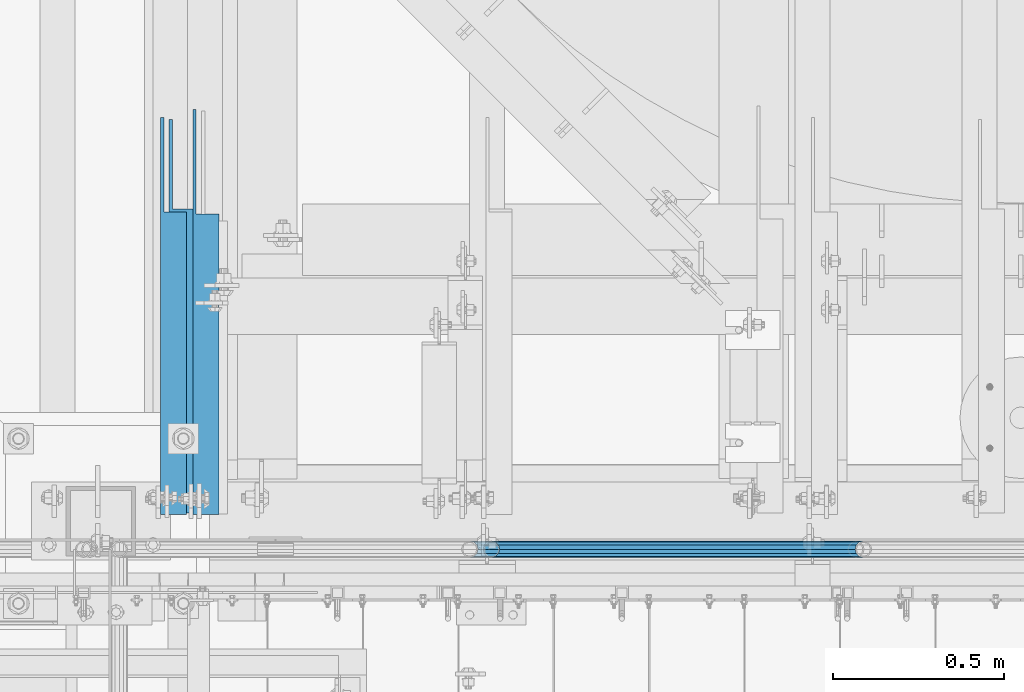
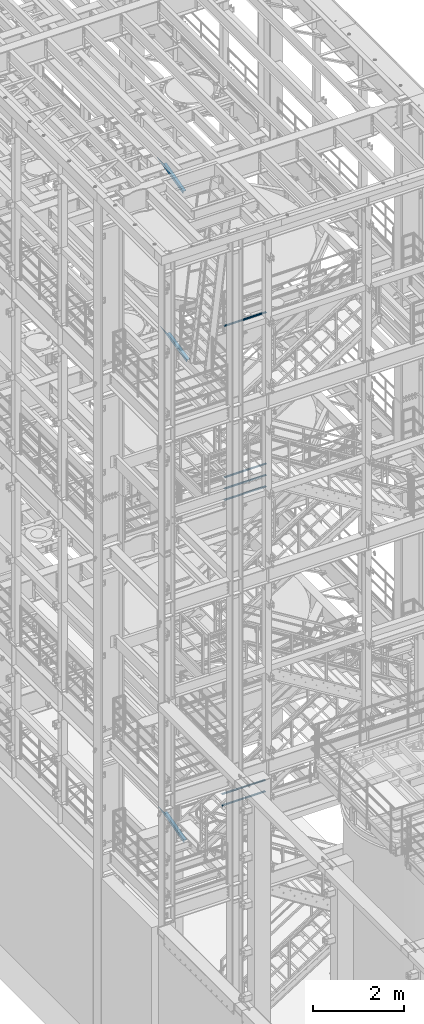
# One storey, part 968 of 1876: 9 beams, 6 elements without a shape of their own.
"""IFC2X3 building model written with IfcOpenShell, lengths in millimetres."""

from ifc_helpers import new_model, si_unit, frame, origin_with_axes, place, context, subcontext, project, spatial, faceted_brep, material, type_object, element, aggregate, save


model = new_model("IFC2X3")

# Units and contexts
model_context = context("Model", 3, precision=1e-05, world=origin_with_axes())
body_context = subcontext(model_context, "Body", "Model", "MODEL_VIEW")
ifc_project = project(units=[si_unit("LENGTHUNIT", "METRE", prefix="MILLI"), si_unit("AREAUNIT", "SQUARE_METRE"), si_unit("VOLUMEUNIT", "CUBIC_METRE"), si_unit("MASSUNIT", "GRAM", prefix="KILO"), si_unit("TIMEUNIT", "SECOND"), si_unit("PLANEANGLEUNIT", "RADIAN"), si_unit("SOLIDANGLEUNIT", "STERADIAN"), si_unit("THERMODYNAMICTEMPERATUREUNIT", "DEGREE_CELSIUS"), si_unit("LUMINOUSINTENSITYUNIT", "LUMEN")], contexts=[model_context])

# Site, building, storey
site_placement = place(None, origin_with_axes())
site = spatial("IfcSite", under=ifc_project, at=site_placement, CompositionType="ELEMENT")
building_placement = place(site_placement, origin_with_axes())
building = spatial("IfcBuilding", under=site, at=building_placement, Name="Undefined", CompositionType="ELEMENT")
storey_placement = place(building_placement, origin_with_axes())
storey = spatial("IfcBuildingStorey", under=building, at=storey_placement, Name="Undefined", CompositionType="ELEMENT", Elevation=0.0)

# Assembly, beams
assembly_1_placement = place(storey_placement, origin_with_axes())
assembly_1 = element("IfcElementAssembly", 1, at=assembly_1_placement, inside=storey, Name="RAIL", AssemblyPlace="NOTDEFINED", PredefinedType="RIGID_FRAME")
ifc_material_1 = material()
beam_type_1 = type_object("IfcBeamType", Name="PIPE1-1/2SCH40", PredefinedType="NOTDEFINED")
beam_1_placement = place(assembly_1_placement, frame((3959.22499997645, -4654.55000114568, 13471.525), z_axis=(0.0, 0.0, 1.0), x_axis=(-1.0, 0.0, 0.0)))
beam_1 = element("IfcBeam", 2, at=beam_1_placement, type_object=beam_type_1, material=ifc_material_1, Name="RAIL", ObjectType="PIPE1-1/2SCH40", context=body_context, shape_type="Brep", body=[
    faceted_brep([(1068.12780699489, -12.0649999999996, 20.8971929933177), (1068.12780699489, -12.064999999986, 15.8661214311942), (1067.63437855703, -10.2235000000001, 17.7076214311801), (1064.89499998821, 0.0, 20.4470000000001), (1064.89499998821, 0.0, 24.1299999999992), (1067.63437855703, 10.2235000000001, 17.7076214311801), (1068.12780699489, 12.0650000000132, 15.8661214311669), (1068.12780699489, 12.0649999999996, 20.8971929933177), (1089.02499998822, 24.1300000000001, 0.0), (1076.95999998821, 20.8971929933186, 12.0650000000005), (1076.95999998821, 20.8971929933186, -12.0650000000005), (1073.77042842606, 17.7076214311801, 10.2235000000001), (1076.50980699488, 20.4470000000001, 0.0), (1073.77042842606, 17.7076214311801, -10.2235000000001), (1068.12780699489, 12.0650000000132, -15.8661214311669), (1068.12780699489, 12.0649999999996, -20.8971929933177), (1067.63437855703, 10.2235000000001, -17.7076214311801), (1064.89499998821, 0.0, -20.4470000000001), (1064.89499998821, 0.0, -24.1299999999992), (1068.12780699489, -12.064999999986, -15.8661214311942), (1068.12780699489, -12.0649999999996, -20.8971929933177), (1067.63437855703, -10.2235000000001, -17.7076214311801), (1089.02499998821, -24.1299999999865, 0.0), (1076.95999998821, -20.8971929933186, -12.0650000000005), (1076.95999998821, -20.8971929933186, 12.0650000000005), (1073.77042842609, -17.7076214311801, -10.2235000000001), (1076.50980699491, -20.4470000000001, 0.0), (1073.77042842609, -17.7076214311801, 10.2235000000001), (12.0650000000064, -20.8971929933177, -12.0649999999987), (20.8971929933249, -12.0650000000005, -20.8971929933177), (0.0, 24.1299999999992, 0.0), (12.0650000000064, 20.8971929933177, -12.0649999999987), (12.0650000000064, 20.8971929933177, 12.0649999999987), (20.8971929933249, 12.0650000000005, 20.8971929933177), (24.1300000000064, 0.0, 24.130000000001), (20.8971929933249, 12.0650000000005, -20.8971929933177), (24.1300000000063, 0.0, -24.130000000001), (24.1300000000063, 0.0, -20.4470000000001), (20.8971929933249, -12.0650000000005, -15.8661214311796), (21.3906214311868, -10.2235000000001, -17.7076214311819), (21.3906214311868, 10.2235000000001, -17.7076214311819), (20.8971929933249, 12.0650000000005, -15.8661214311796), (15.2545715621445, 17.7076214311801, -10.2235000000001), (12.5151929933249, 20.4470000000001, 0.0), (15.2545715621445, 17.7076214311801, 10.2235000000001), (20.8971929933249, 12.0650000000005, 15.8661214311796), (21.3906214311868, 10.2235000000001, 17.7076214311819), (24.1300000000064, 0.0, 20.4470000000001), (21.3906214311868, -10.2235000000001, 17.7076214311819), (20.8971929933249, -12.0650000000005, 15.8661214311796), (20.8971929933249, -12.0650000000005, 20.8971929933177), (12.0650000000064, -20.8971929933177, 12.0649999999987), (0.0, -24.1299999999992, 0.0), (15.2545715621445, -17.7076214311801, 10.2235000000001), (12.5151929933249, -20.4470000000001, 0.0), (15.2545715621445, -17.7076214311801, -10.2235000000001)], [[[0, 1, 2, 3, 4]], [[4, 3, 5, 6, 7]], [[8, 9, 10]], [[7, 6, 11, 12, 13, 14, 15, 10, 9]], [[16, 17, 18, 15, 14]], [[19, 20, 18, 17, 21]], [[22, 23, 24]], [[24, 23, 20, 19, 25, 26, 27, 1, 0]], [[28, 29, 20, 23]], [[30, 31, 32]], [[33, 34, 4, 7]], [[32, 33, 7, 9]], [[30, 32, 9, 8]], [[31, 30, 8, 10]], [[35, 31, 10, 15]], [[36, 35, 15, 18]], [[29, 36, 18, 20]], [[37, 36, 29, 38, 39]], [[40, 41, 35, 36, 37]], [[32, 31, 35, 41, 42, 43, 44, 45, 33]], [[33, 45, 46, 47, 34]], [[34, 47, 48, 49, 50]], [[34, 50, 0, 4]], [[50, 51, 24, 0]], [[51, 52, 22, 24]], [[52, 28, 23, 22]], [[51, 28, 52]], [[50, 49, 53, 54, 55, 38, 29, 28, 51]], [[55, 54, 26, 25]], [[21, 39, 38, 55, 25, 19]], [[37, 39, 21, 17]], [[40, 37, 17, 16]], [[42, 41, 40, 16, 14, 13]], [[43, 42, 13, 12]], [[44, 43, 12, 11]], [[5, 46, 45, 44, 11, 6]], [[47, 46, 5, 3]], [[48, 47, 3, 2]], [[53, 49, 48, 2, 1, 27]], [[54, 53, 27, 26]]]),
])
beam_2_placement = place(assembly_1_placement, frame((2870.19999998823, -4654.55000114568, 13776.325), z_axis=(0.0, 0.0, -1.0), x_axis=(1.0, 0.0, 0.0)))
beam_2 = element("IfcBeam", 3, at=beam_2_placement, type_object=beam_type_1, material=ifc_material_1, Name="RAIL", ObjectType="PIPE1-1/2SCH40", context=body_context, shape_type="Brep", body=[
    faceted_brep([(0.0, 24.1299999999992, 0.0), (12.0650000000064, 20.8971929933177, -12.0649999999987), (12.0650000000064, 20.8971929933177, 12.0649999999987), (12.0650000000064, -20.8971929933177, 12.0649999999987), (12.0650000000064, -20.8971929933177, -12.0649999999987), (0.0, -24.1299999999992, 0.0), (20.8971929933249, -12.0650000000005, 20.8971929933177), (20.8971929933249, -12.0650000000005, 15.8661214311796), (15.2545715621445, -17.7076214311801, 10.2235000000001), (12.5151929933249, -20.4470000000001, 0.0), (15.2545715621445, -17.7076214311801, -10.2235000000001), (20.8971929933249, -12.0650000000005, -15.8661214311796), (20.8971929933249, -12.0650000000005, -20.8971929933177), (24.1300000000063, 0.0, -20.4470000000001), (24.1300000000063, 0.0, -24.130000000001), (21.3906214311868, -10.2235000000001, -17.7076214311819), (21.3906214311868, 10.2235000000001, -17.7076214311819), (20.8971929933249, 12.0650000000005, -15.8661214311796), (20.8971929933249, 12.0650000000005, -20.8971929933177), (15.2545715621445, 17.7076214311801, -10.2235000000001), (12.5151929933249, 20.4470000000001, 0.0), (15.2545715621445, 17.7076214311801, 10.2235000000001), (20.8971929933249, 12.0650000000005, 15.8661214311796), (20.8971929933249, 12.0650000000005, 20.8971929933177), (21.3906214311868, 10.2235000000001, 17.7076214311819), (24.1300000000064, 0.0, 20.4470000000001), (24.1300000000064, 0.0, 24.130000000001), (21.3906214311868, -10.2235000000001, 17.7076214311819), (1089.02499998822, 24.1300000000001, 0.0), (1076.95999998821, 20.8971929933186, -12.0650000000005), (1068.12780699489, 12.0649999999996, -20.8971929933177), (1089.02499998821, -24.1299999999865, 0.0), (1076.95999998821, -20.8971929933186, -12.0650000000005), (1076.95999998821, -20.8971929933186, 12.0650000000005), (1068.12780699489, -12.0649999999996, 20.8971929933177), (1068.12780699489, -12.0649999999996, -20.8971929933177), (1064.89499998821, 0.0, -24.1299999999992), (1067.63437855703, 10.2235000000001, -17.7076214311801), (1064.89499998821, 0.0, -20.4470000000001), (1068.12780699489, 12.0650000000132, -15.8661214311669), (1068.12780699489, -12.064999999986, -15.8661214311942), (1067.63437855703, -10.2235000000001, -17.7076214311801), (1073.77042842609, -17.7076214311801, -10.2235000000001), (1076.50980699491, -20.4470000000001, 0.0), (1073.77042842609, -17.7076214311801, 10.2235000000001), (1068.12780699489, -12.064999999986, 15.8661214311942), (1067.63437855703, -10.2235000000001, 17.7076214311801), (1064.89499998821, 0.0, 20.4470000000001), (1064.89499998821, 0.0, 24.1299999999992), (1068.12780699489, 12.0649999999996, 20.8971929933177), (1076.95999998821, 20.8971929933186, 12.0650000000005), (1068.12780699489, 12.0650000000132, 15.8661214311669), (1073.77042842606, 17.7076214311801, 10.2235000000001), (1076.50980699488, 20.4470000000001, 0.0), (1073.77042842606, 17.7076214311801, -10.2235000000001), (1067.63437855703, 10.2235000000001, 17.7076214311801)], [[[0, 1, 2]], [[3, 4, 5]], [[6, 7, 8, 9, 10, 11, 12, 4, 3]], [[13, 14, 12, 11, 15]], [[16, 17, 18, 14, 13]], [[2, 1, 18, 17, 19, 20, 21, 22, 23]], [[23, 22, 24, 25, 26]], [[26, 25, 27, 7, 6]], [[1, 0, 28, 29]], [[18, 1, 29, 30]], [[31, 32, 33]], [[6, 3, 33, 34]], [[3, 5, 31, 33]], [[5, 4, 32, 31]], [[4, 12, 35, 32]], [[12, 14, 36, 35]], [[14, 18, 30, 36]], [[37, 38, 36, 30, 39]], [[40, 35, 36, 38, 41]], [[33, 32, 35, 40, 42, 43, 44, 45, 34]], [[34, 45, 46, 47, 48]], [[26, 6, 34, 48]], [[2, 23, 49, 50]], [[23, 26, 48, 49]], [[0, 2, 50, 28]], [[28, 50, 29]], [[49, 51, 52, 53, 54, 39, 30, 29, 50]], [[48, 47, 55, 51, 49]], [[25, 24, 55, 47]], [[55, 24, 22, 21, 52, 51]], [[21, 20, 53, 52]], [[20, 19, 54, 53]], [[19, 17, 16, 37, 39, 54]], [[16, 13, 38, 37]], [[13, 15, 41, 38]], [[41, 15, 11, 10, 42, 40]], [[10, 9, 43, 42]], [[9, 8, 44, 43]], [[8, 7, 27, 46, 45, 44]], [[27, 25, 47, 46]]]),
])
beam_3_placement = place(assembly_1_placement, frame((2870.19999998823, -4654.55000114568, 14081.125), z_axis=(0.0, 0.0, -1.0), x_axis=(1.0, 0.0, 0.0)))
beam_3 = element("IfcBeam", 4, at=beam_3_placement, type_object=beam_type_1, material=ifc_material_1, Name="RAIL", ObjectType="PIPE1-1/2SCH40", context=body_context, shape_type="Brep", body=[
    faceted_brep([(0.0, 24.1299999999992, 0.0), (12.0650000000064, 20.8971929933177, -12.0649999999987), (12.0650000000064, 20.8971929933177, 12.0649999999987), (12.0650000000064, -20.8971929933177, 12.0649999999987), (12.0650000000064, -20.8971929933177, -12.0649999999987), (0.0, -24.1299999999992, 0.0), (20.8971929933249, -12.0650000000005, 20.8971929933177), (20.8971929933249, -12.0650000000005, 15.8661214311796), (15.2545715621445, -17.7076214311801, 10.2235000000001), (12.5151929933249, -20.4470000000001, 0.0), (15.2545715621445, -17.7076214311801, -10.2235000000001), (20.8971929933249, -12.0650000000005, -15.8661214311796), (20.8971929933249, -12.0650000000005, -20.8971929933177), (24.1300000000063, 0.0, -20.4470000000001), (24.1300000000063, 0.0, -24.130000000001), (21.3906214311868, -10.2235000000001, -17.7076214311819), (21.3906214311868, 10.2235000000001, -17.7076214311819), (20.8971929933249, 12.0650000000005, -15.8661214311796), (20.8971929933249, 12.0650000000005, -20.8971929933177), (15.2545715621445, 17.7076214311801, -10.2235000000001), (12.5151929933249, 20.4470000000001, 0.0), (15.2545715621445, 17.7076214311801, 10.2235000000001), (20.8971929933249, 12.0650000000005, 15.8661214311796), (20.8971929933249, 12.0650000000005, 20.8971929933177), (21.3906214311868, 10.2235000000001, 17.7076214311819), (24.1300000000064, 0.0, 20.4470000000001), (24.1300000000064, 0.0, 24.130000000001), (21.3906214311868, -10.2235000000001, 17.7076214311819), (1089.02499998822, 24.1300000000001, 0.0), (1076.95999998821, 20.8971929933186, -12.0650000000005), (1068.12780699489, 12.0649999999996, -20.8971929933177), (1089.02499998821, -24.1299999999865, 0.0), (1076.95999998821, -20.8971929933186, -12.0650000000005), (1076.95999998821, -20.8971929933186, 12.0650000000005), (1068.12780699489, -12.0649999999996, 20.8971929933177), (1068.12780699489, -12.0649999999996, -20.8971929933177), (1064.89499998821, 0.0, -24.1299999999992), (1067.63437855703, 10.2235000000001, -17.7076214311801), (1064.89499998821, 0.0, -20.4470000000001), (1068.12780699489, 12.0650000000132, -15.8661214311669), (1068.12780699489, -12.064999999986, -15.8661214311942), (1067.63437855703, -10.2235000000001, -17.7076214311801), (1073.77042842609, -17.7076214311801, -10.2235000000001), (1076.50980699491, -20.4470000000001, 0.0), (1073.77042842609, -17.7076214311801, 10.2235000000001), (1068.12780699489, -12.064999999986, 15.8661214311942), (1067.63437855703, -10.2235000000001, 17.7076214311801), (1064.89499998821, 0.0, 20.4470000000001), (1064.89499998821, 0.0, 24.1299999999992), (1068.12780699489, 12.0649999999996, 20.8971929933177), (1076.95999998821, 20.8971929933186, 12.0650000000005), (1068.12780699489, 12.0650000000132, 15.8661214311669), (1073.77042842606, 17.7076214311801, 10.2235000000001), (1076.50980699488, 20.4470000000001, 0.0), (1073.77042842606, 17.7076214311801, -10.2235000000001), (1067.63437855703, 10.2235000000001, 17.7076214311801)], [[[0, 1, 2]], [[3, 4, 5]], [[6, 7, 8, 9, 10, 11, 12, 4, 3]], [[13, 14, 12, 11, 15]], [[16, 17, 18, 14, 13]], [[2, 1, 18, 17, 19, 20, 21, 22, 23]], [[23, 22, 24, 25, 26]], [[26, 25, 27, 7, 6]], [[1, 0, 28, 29]], [[18, 1, 29, 30]], [[31, 32, 33]], [[6, 3, 33, 34]], [[3, 5, 31, 33]], [[5, 4, 32, 31]], [[4, 12, 35, 32]], [[12, 14, 36, 35]], [[14, 18, 30, 36]], [[37, 38, 36, 30, 39]], [[40, 35, 36, 38, 41]], [[33, 32, 35, 40, 42, 43, 44, 45, 34]], [[34, 45, 46, 47, 48]], [[26, 6, 34, 48]], [[2, 23, 49, 50]], [[23, 26, 48, 49]], [[0, 2, 50, 28]], [[28, 50, 29]], [[49, 51, 52, 53, 54, 39, 30, 29, 50]], [[48, 47, 55, 51, 49]], [[25, 24, 55, 47]], [[55, 24, 22, 21, 52, 51]], [[21, 20, 53, 52]], [[20, 19, 54, 53]], [[19, 17, 16, 37, 39, 54]], [[16, 13, 38, 37]], [[13, 15, 41, 38]], [[41, 15, 11, 10, 42, 40]], [[10, 9, 43, 42]], [[9, 8, 44, 43]], [[8, 7, 27, 46, 45, 44]], [[27, 25, 47, 46]]]),
])
aggregate(assembly_1, [beam_1, beam_2, beam_3])

assembly_2_placement = place(storey_placement, origin_with_axes())
assembly_2 = element("IfcElementAssembly", 5, at=assembly_2_placement, inside=storey, Name="RAIL", AssemblyPlace="NOTDEFINED", PredefinedType="RIGID_FRAME")
beam_4_placement = place(assembly_2_placement, frame((2806.70000023354, -4654.55000114549, 5292.725), z_axis=(0.0, 0.0, 1.0), x_axis=(1.0, 0.0, 0.0)))
beam_4 = element("IfcBeam", 6, at=beam_4_placement, type_object=beam_type_1, material=ifc_material_1, Name="RAIL", ObjectType="PIPE1-1/2SCH40", context=body_context, shape_type="Brep", body=[
    faceted_brep([(1109.40280692884, -12.0649999999996, 20.8971929933186), (1109.40280692884, -12.0650000000269, 15.8661214311533), (1108.90937849097, -10.2235000000001, 17.7076214311801), (1106.16999992216, -9.09494701772928e-13, 20.4470000000001), (1106.16999992216, -9.09494701772928e-13, 24.1300000000001), (1108.90937849099, 10.2235000000001, 17.7076214311801), (1109.40280692884, 12.0649999999723, 15.8661214312078), (1109.40280692884, 12.0649999999996, 20.8971929933186), (1130.29999992215, 24.1300000000001, 0.0), (1118.23499992216, 20.8971929933186, 12.0649999999996), (1118.23499992216, 20.8971929933186, -12.0649999999996), (1115.04542836005, 17.7076214311801, 10.2235000000001), (1117.78480692887, 20.4470000000001, 0.0), (1115.04542836005, 17.7076214311801, -10.2235000000001), (1109.40280692884, 12.0649999999723, -15.8661214312078), (1109.40280692884, 12.0649999999996, -20.8971929933186), (1108.90937849099, 10.2235000000001, -17.7076214311801), (1106.16999992216, 0.0, -20.4470000000001), (1106.16999992216, 0.0, -24.1300000000001), (1109.40280692884, -12.0650000000269, -15.8661214311533), (1109.40280692884, -12.0649999999996, -20.8971929933186), (1108.90937849097, -10.2235000000001, -17.7076214311801), (1130.29999992216, -24.1300000000274, 0.0), (1118.23499992216, -20.8971929933186, -12.0649999999996), (1118.23499992216, -20.8971929933186, 12.0649999999996), (1115.04542835999, -17.7076214311801, -10.2235000000001), (1117.78480692881, -20.4470000000001, 0.0), (1115.04542835999, -17.7076214311801, 10.2235000000001), (12.0650000000064, -20.8971929933177, -12.0649999999987), (20.8971929933249, -12.0650000000005, -20.8971929933177), (0.0, 24.1299999999992, 0.0), (12.0650000000064, 20.8971929933177, -12.0649999999987), (12.0650000000064, 20.8971929933177, 12.0649999999987), (20.8971929933249, 12.0650000000005, 20.8971929933177), (24.1300000000064, 0.0, 24.130000000001), (20.8971929933249, 12.0650000000005, -20.8971929933177), (24.1300000000063, 0.0, -24.130000000001), (24.1300000000063, 0.0, -20.4470000000001), (20.8971929933249, -12.0650000000005, -15.8661214311796), (21.3906214311868, -10.2235000000001, -17.7076214311819), (21.3906214311868, 10.2235000000001, -17.7076214311819), (20.8971929933249, 12.0650000000005, -15.8661214311796), (15.2545715621445, 17.7076214311801, -10.2235000000001), (12.5151929933249, 20.4470000000001, 0.0), (15.2545715621445, 17.7076214311801, 10.2235000000001), (20.8971929933249, 12.0650000000005, 15.8661214311796), (21.3906214311868, 10.2235000000001, 17.7076214311819), (24.1300000000064, 0.0, 20.4470000000001), (21.3906214311868, -10.2235000000001, 17.7076214311819), (20.8971929933249, -12.0650000000005, 15.8661214311796), (20.8971929933249, -12.0650000000005, 20.8971929933177), (12.0650000000064, -20.8971929933177, 12.0649999999987), (0.0, -24.1299999999992, 0.0), (15.2545715621445, -17.7076214311801, 10.2235000000001), (12.5151929933249, -20.4470000000001, 0.0), (15.2545715621445, -17.7076214311801, -10.2235000000001)], [[[0, 1, 2, 3, 4]], [[4, 3, 5, 6, 7]], [[8, 9, 10]], [[7, 6, 11, 12, 13, 14, 15, 10, 9]], [[16, 17, 18, 15, 14]], [[19, 20, 18, 17, 21]], [[22, 23, 24]], [[24, 23, 20, 19, 25, 26, 27, 1, 0]], [[28, 29, 20, 23]], [[30, 31, 32]], [[33, 34, 4, 7]], [[32, 33, 7, 9]], [[30, 32, 9, 8]], [[31, 30, 8, 10]], [[35, 31, 10, 15]], [[36, 35, 15, 18]], [[29, 36, 18, 20]], [[37, 36, 29, 38, 39]], [[40, 41, 35, 36, 37]], [[32, 31, 35, 41, 42, 43, 44, 45, 33]], [[33, 45, 46, 47, 34]], [[34, 47, 48, 49, 50]], [[34, 50, 0, 4]], [[50, 51, 24, 0]], [[51, 52, 22, 24]], [[52, 28, 23, 22]], [[51, 28, 52]], [[50, 49, 53, 54, 55, 38, 29, 28, 51]], [[55, 54, 26, 25]], [[21, 39, 38, 55, 25, 19]], [[37, 39, 21, 17]], [[40, 37, 17, 16]], [[42, 41, 40, 16, 14, 13]], [[43, 42, 13, 12]], [[44, 43, 12, 11]], [[5, 46, 45, 44, 11, 6]], [[47, 46, 5, 3]], [[48, 47, 3, 2]], [[53, 49, 48, 2, 1, 27]], [[54, 53, 27, 26]]]),
])
beam_5_placement = place(assembly_2_placement, frame((3937.00000015569, -4654.55000114549, 5597.525), z_axis=(0.0, 0.0, -1.0), x_axis=(-1.0, 0.0, 0.0)))
beam_5 = element("IfcBeam", 7, at=beam_5_placement, type_object=beam_type_1, material=ifc_material_1, Name="RAIL", ObjectType="PIPE1-1/2SCH40", context=body_context, shape_type="Brep", body=[
    faceted_brep([(0.0, 24.1299999999992, 0.0), (12.0650000000064, 20.8971929933177, -12.0649999999987), (12.0650000000064, 20.8971929933177, 12.0649999999987), (12.0650000000064, -20.8971929933177, 12.0649999999987), (12.0650000000064, -20.8971929933177, -12.0649999999987), (0.0, -24.1299999999992, 0.0), (20.8971929933249, -12.0650000000005, 20.8971929933177), (20.8971929933249, -12.0650000000005, 15.8661214311796), (15.2545715621445, -17.7076214311801, 10.2235000000001), (12.5151929933249, -20.4470000000001, 0.0), (15.2545715621445, -17.7076214311801, -10.2235000000001), (20.8971929933249, -12.0650000000005, -15.8661214311796), (20.8971929933249, -12.0650000000005, -20.8971929933177), (24.1300000000063, 0.0, -20.4470000000001), (24.1300000000063, 0.0, -24.130000000001), (21.3906214311868, -10.2235000000001, -17.7076214311819), (21.3906214311868, 10.2235000000001, -17.7076214311819), (20.8971929933249, 12.0650000000005, -15.8661214311796), (20.8971929933249, 12.0650000000005, -20.8971929933177), (15.2545715621445, 17.7076214311801, -10.2235000000001), (12.5151929933249, 20.4470000000001, 0.0), (15.2545715621445, 17.7076214311801, 10.2235000000001), (20.8971929933249, 12.0650000000005, 15.8661214311796), (20.8971929933249, 12.0650000000005, 20.8971929933177), (21.3906214311868, 10.2235000000001, 17.7076214311819), (24.1300000000064, 0.0, 20.4470000000001), (24.1300000000064, 0.0, 24.130000000001), (21.3906214311868, -10.2235000000001, 17.7076214311819), (1130.29999992215, 24.1300000000001, 0.0), (1118.23499992216, 20.8971929933186, -12.0649999999996), (1109.40280692884, 12.0649999999996, -20.8971929933186), (1130.29999992216, -24.1300000000274, 0.0), (1118.23499992216, -20.8971929933186, -12.0649999999996), (1118.23499992216, -20.8971929933186, 12.0649999999996), (1109.40280692884, -12.0649999999996, 20.8971929933186), (1109.40280692884, -12.0649999999996, -20.8971929933186), (1106.16999992216, 0.0, -24.1300000000001), (1108.90937849099, 10.2235000000001, -17.7076214311801), (1106.16999992216, 0.0, -20.4470000000001), (1109.40280692884, 12.0649999999723, -15.8661214312078), (1109.40280692884, -12.0650000000269, -15.8661214311533), (1108.90937849097, -10.2235000000001, -17.7076214311801), (1115.04542835999, -17.7076214311801, -10.2235000000001), (1117.78480692881, -20.4470000000001, 0.0), (1115.04542835999, -17.7076214311801, 10.2235000000001), (1109.40280692884, -12.0650000000269, 15.8661214311533), (1108.90937849097, -10.2235000000001, 17.7076214311801), (1106.16999992216, -9.09494701772928e-13, 20.4470000000001), (1106.16999992216, -9.09494701772928e-13, 24.1300000000001), (1109.40280692884, 12.0649999999996, 20.8971929933186), (1118.23499992216, 20.8971929933186, 12.0649999999996), (1109.40280692884, 12.0649999999723, 15.8661214312078), (1115.04542836005, 17.7076214311801, 10.2235000000001), (1117.78480692887, 20.4470000000001, 0.0), (1115.04542836005, 17.7076214311801, -10.2235000000001), (1108.90937849099, 10.2235000000001, 17.7076214311801)], [[[0, 1, 2]], [[3, 4, 5]], [[6, 7, 8, 9, 10, 11, 12, 4, 3]], [[13, 14, 12, 11, 15]], [[16, 17, 18, 14, 13]], [[2, 1, 18, 17, 19, 20, 21, 22, 23]], [[23, 22, 24, 25, 26]], [[26, 25, 27, 7, 6]], [[1, 0, 28, 29]], [[18, 1, 29, 30]], [[31, 32, 33]], [[6, 3, 33, 34]], [[3, 5, 31, 33]], [[5, 4, 32, 31]], [[4, 12, 35, 32]], [[12, 14, 36, 35]], [[14, 18, 30, 36]], [[37, 38, 36, 30, 39]], [[40, 35, 36, 38, 41]], [[33, 32, 35, 40, 42, 43, 44, 45, 34]], [[34, 45, 46, 47, 48]], [[26, 6, 34, 48]], [[2, 23, 49, 50]], [[23, 26, 48, 49]], [[0, 2, 50, 28]], [[28, 50, 29]], [[49, 51, 52, 53, 54, 39, 30, 29, 50]], [[48, 47, 55, 51, 49]], [[25, 24, 55, 47]], [[55, 24, 22, 21, 52, 51]], [[21, 20, 53, 52]], [[20, 19, 54, 53]], [[19, 17, 16, 37, 39, 54]], [[16, 13, 38, 37]], [[13, 15, 41, 38]], [[41, 15, 11, 10, 42, 40]], [[10, 9, 43, 42]], [[9, 8, 44, 43]], [[8, 7, 27, 46, 45, 44]], [[27, 25, 47, 46]]]),
])
aggregate(assembly_2, [beam_4, beam_5])

# Assembly, beam
assembly_3_placement = place(storey_placement, origin_with_axes())
assembly_3 = element("IfcElementAssembly", 8, at=assembly_3_placement, inside=storey, Name="RAIL", AssemblyPlace="NOTDEFINED", PredefinedType="RIGID_FRAME")
beam_6_placement = place(assembly_3_placement, frame((3959.22499997646, -4654.55000114554, 18145.125), z_axis=(0.0, 0.0, 1.0), x_axis=(-1.0, 0.0, 0.0)))
beam_6 = element("IfcBeam", 9, at=beam_6_placement, type_object=beam_type_1, material=ifc_material_1, Name="RAIL", ObjectType="PIPE1-1/2SCH40", context=body_context, shape_type="Brep", body=[
    faceted_brep([(1068.12780699489, -12.0649999999996, 20.8971929933177), (1068.12780699489, -12.064999999986, 15.8661214311942), (1067.63437855703, -10.2235000000001, 17.7076214311801), (1064.89499998821, 0.0, 20.4470000000001), (1064.89499998821, 0.0, 24.1299999999992), (1067.63437855703, 10.2235000000001, 17.7076214311801), (1068.12780699489, 12.0650000000132, 15.8661214311669), (1068.12780699489, 12.0649999999996, 20.8971929933177), (1089.02499998822, 24.1300000000001, 0.0), (1076.95999998821, 20.8971929933186, 12.0650000000005), (1076.95999998821, 20.8971929933186, -12.0650000000005), (1073.77042842606, 17.7076214311801, 10.2235000000001), (1076.50980699488, 20.4470000000001, 0.0), (1073.77042842606, 17.7076214311801, -10.2235000000001), (1068.12780699489, 12.0650000000132, -15.8661214311669), (1068.12780699489, 12.0649999999996, -20.8971929933177), (1067.63437855703, 10.2235000000001, -17.7076214311801), (1064.89499998821, 0.0, -20.4470000000001), (1064.89499998821, 0.0, -24.1299999999992), (1068.12780699489, -12.064999999986, -15.8661214311942), (1068.12780699489, -12.0649999999996, -20.8971929933177), (1067.63437855703, -10.2235000000001, -17.7076214311801), (1089.02499998821, -24.1299999999865, 0.0), (1076.95999998821, -20.8971929933186, -12.0650000000005), (1076.95999998821, -20.8971929933186, 12.0650000000005), (1073.77042842609, -17.7076214311801, -10.2235000000001), (1076.50980699491, -20.4470000000001, 0.0), (1073.77042842609, -17.7076214311801, 10.2235000000001), (12.0650000000064, -20.8971929933177, -12.0649999999987), (20.8971929933249, -12.0650000000005, -20.8971929933177), (0.0, 24.1299999999992, 0.0), (12.0650000000064, 20.8971929933177, -12.0649999999987), (12.0650000000064, 20.8971929933177, 12.0649999999987), (20.8971929933249, 12.0650000000005, 20.8971929933177), (24.1300000000064, 0.0, 24.130000000001), (20.8971929933249, 12.0650000000005, -20.8971929933177), (24.1300000000063, 0.0, -24.130000000001), (24.1300000000063, 0.0, -20.4470000000001), (20.8971929933249, -12.0650000000005, -15.8661214311796), (21.3906214311868, -10.2235000000001, -17.7076214311819), (21.3906214311868, 10.2235000000001, -17.7076214311819), (20.8971929933249, 12.0650000000005, -15.8661214311796), (15.2545715621445, 17.7076214311801, -10.2235000000001), (12.5151929933249, 20.4470000000001, 0.0), (15.2545715621445, 17.7076214311801, 10.2235000000001), (20.8971929933249, 12.0650000000005, 15.8661214311796), (21.3906214311868, 10.2235000000001, 17.7076214311819), (24.1300000000064, 0.0, 20.4470000000001), (21.3906214311868, -10.2235000000001, 17.7076214311819), (20.8971929933249, -12.0650000000005, 15.8661214311796), (20.8971929933249, -12.0650000000005, 20.8971929933177), (12.0650000000064, -20.8971929933177, 12.0649999999987), (0.0, -24.1299999999992, 0.0), (15.2545715621445, -17.7076214311801, 10.2235000000001), (12.5151929933249, -20.4470000000001, 0.0), (15.2545715621445, -17.7076214311801, -10.2235000000001)], [[[0, 1, 2, 3, 4]], [[4, 3, 5, 6, 7]], [[8, 9, 10]], [[7, 6, 11, 12, 13, 14, 15, 10, 9]], [[16, 17, 18, 15, 14]], [[19, 20, 18, 17, 21]], [[22, 23, 24]], [[24, 23, 20, 19, 25, 26, 27, 1, 0]], [[28, 29, 20, 23]], [[30, 31, 32]], [[33, 34, 4, 7]], [[32, 33, 7, 9]], [[30, 32, 9, 8]], [[31, 30, 8, 10]], [[35, 31, 10, 15]], [[36, 35, 15, 18]], [[29, 36, 18, 20]], [[37, 36, 29, 38, 39]], [[40, 41, 35, 36, 37]], [[32, 31, 35, 41, 42, 43, 44, 45, 33]], [[33, 45, 46, 47, 34]], [[34, 47, 48, 49, 50]], [[34, 50, 0, 4]], [[50, 51, 24, 0]], [[51, 52, 22, 24]], [[52, 28, 23, 22]], [[51, 28, 52]], [[50, 49, 53, 54, 55, 38, 29, 28, 51]], [[55, 54, 26, 25]], [[21, 39, 38, 55, 25, 19]], [[37, 39, 21, 17]], [[40, 37, 17, 16]], [[42, 41, 40, 16, 14, 13]], [[43, 42, 13, 12]], [[44, 43, 12, 11]], [[5, 46, 45, 44, 11, 6]], [[47, 46, 5, 3]], [[48, 47, 3, 2]], [[53, 49, 48, 2, 1, 27]], [[54, 53, 27, 26]]]),
])
aggregate(assembly_3, [beam_6])

assembly_4_placement = place(storey_placement, origin_with_axes())
assembly_4 = element("IfcElementAssembly", 10, at=assembly_4_placement, inside=storey, AssemblyPlace="NOTDEFINED", PredefinedType="RIGID_FRAME")
ifc_material_2 = material(Name="STEEL/A36")
beam_type_2 = type_object("IfcBeamType", Name="L3X3X3/8", PredefinedType="NOTDEFINED")
beam_7_placement = place(assembly_4_placement, frame((1965.325, -4562.3143433578, 4558.96418871958), z_axis=(1.0, 0.0, 0.0), x_axis=(0.0, 0.967147277703795, 0.254216724922138)))
beam_7 = element("IfcBeam", 11, at=beam_7_placement, type_object=beam_type_2, material=ifc_material_2, ObjectType="L3X3X3/8", context=body_context, shape_type="Brep", body=[
    faceted_brep([(23.7928828385348, 38.099999999994, -38.1000000000004), (23.7928828385348, 38.099999999994, 38.1000000000004), (905.477403464634, 38.1000000000176, 38.1000000000004), (905.477403464634, 38.1000000000176, -38.1000000000004), (23.7809703256453, 28.5749999999953, 38.1000000000004), (941.714507152235, 28.5750000000207, 38.1000000000004), (23.7809703256453, 28.5749999999953, -28.5749999999998), (941.714507152235, 28.5750000000207, -28.5749999999998), (23.6975827354227, -38.0999999999913, -28.5749999999998), (1195.37423296544, -38.0999999999585, -28.5749999999998), (23.6975827354227, -38.0999999999913, -38.1000000000004), (1195.37423296544, -38.0999999999585, -38.1000000000004)], [[[0, 1, 2, 3]], [[1, 4, 5, 2]], [[4, 6, 7, 5]], [[6, 8, 9, 7]], [[8, 10, 11, 9]], [[10, 0, 3, 11]], [[5, 7, 9, 11, 3, 2]], [[10, 8, 6, 4, 1, 0]]]),
])
aggregate(assembly_4, [beam_7])

assembly_5_placement = place(storey_placement, origin_with_axes())
assembly_5 = element("IfcElementAssembly", 12, at=assembly_5_placement, inside=storey, AssemblyPlace="NOTDEFINED", PredefinedType="RIGID_FRAME")
beam_8_placement = place(assembly_5_placement, frame((1939.92500019074, -4562.78281844778, 21997.5317219592), z_axis=(1.0, 0.0, 0.0), x_axis=(0.0, 0.97029600569138, 0.241920774923019)))
beam_8 = element("IfcBeam", 13, at=beam_8_placement, type_object=beam_type_2, material=ifc_material_2, ObjectType="L3X3X3/8", context=body_context, shape_type="Brep", body=[
    faceted_brep([(20.4512332895073, 38.1000000000495, -38.0999999999999), (20.4512332895073, 38.1000000000495, 38.0999999999999), (892.440924395522, 38.0999999997366, 38.0999999999999), (892.440924395522, 38.0999999997366, -38.0999999999999), (20.4512332895037, 28.5750000000371, 38.0999999999999), (930.643800759319, 28.5749999997061, 38.0999999999999), (20.4512332895037, 28.5750000000371, -28.575), (930.643800759319, 28.5749999997061, -28.575), (20.4512332894728, -38.1000000000604, -28.575), (1198.0639353059, -38.1000000004824, -28.575), (20.4512332894728, -38.1000000000604, -38.0999999999999), (1198.0639353059, -38.1000000004824, -38.0999999999999)], [[[0, 1, 2, 3]], [[1, 4, 5, 2]], [[4, 6, 7, 5]], [[6, 8, 9, 7]], [[8, 10, 11, 9]], [[10, 0, 3, 11]], [[5, 7, 9, 11, 3, 2]], [[10, 8, 6, 4, 1, 0]]]),
])
aggregate(assembly_5, [beam_8])

assembly_6_placement = place(storey_placement, origin_with_axes())
assembly_6 = element("IfcElementAssembly", 14, at=assembly_6_placement, inside=storey, AssemblyPlace="NOTDEFINED", PredefinedType="RIGID_FRAME")
beam_9_placement = place(assembly_6_placement, frame((2034.38113645128, -4563.68207182049, 17440.3168585617), z_axis=(1.0, 0.0, 0.0), x_axis=(0.0, 0.975877609643754, 0.218318324920272)))
beam_9 = element("IfcBeam", 15, at=beam_9_placement, type_object=beam_type_2, material=ifc_material_2, ObjectType="L3X3X3/8", context=body_context, shape_type="Brep", body=[
    faceted_brep([(20.3342609810188, 38.0999999999731, -38.0999999999999), (20.3342609810188, 38.0999999999731, 38.1000000000001), (876.597072566308, 38.1000000010754, 38.1000000000001), (876.597072566308, 38.1000000010754, -38.0999999999999), (20.3342609810056, 28.5749999999862, 38.1000000000001), (919.173591213003, 28.5750000011431, 38.1000000000001), (20.3342609810056, 28.5749999999862, -28.575), (919.173591213003, 28.5750000011431, -28.575), (20.3342609809133, -38.0999999999149, -28.575), (1217.20922173987, -38.099999998376, -28.575), (20.3342609809133, -38.0999999999149, -38.0999999999999), (1217.20922173987, -38.099999998376, -38.0999999999999)], [[[0, 1, 2, 3]], [[1, 4, 5, 2]], [[4, 6, 7, 5]], [[6, 8, 9, 7]], [[8, 10, 11, 9]], [[10, 0, 3, 11]], [[5, 7, 9, 11, 3, 2]], [[10, 8, 6, 4, 1, 0]]]),
])
aggregate(assembly_6, [beam_9])

save(model, "model.ifc")
